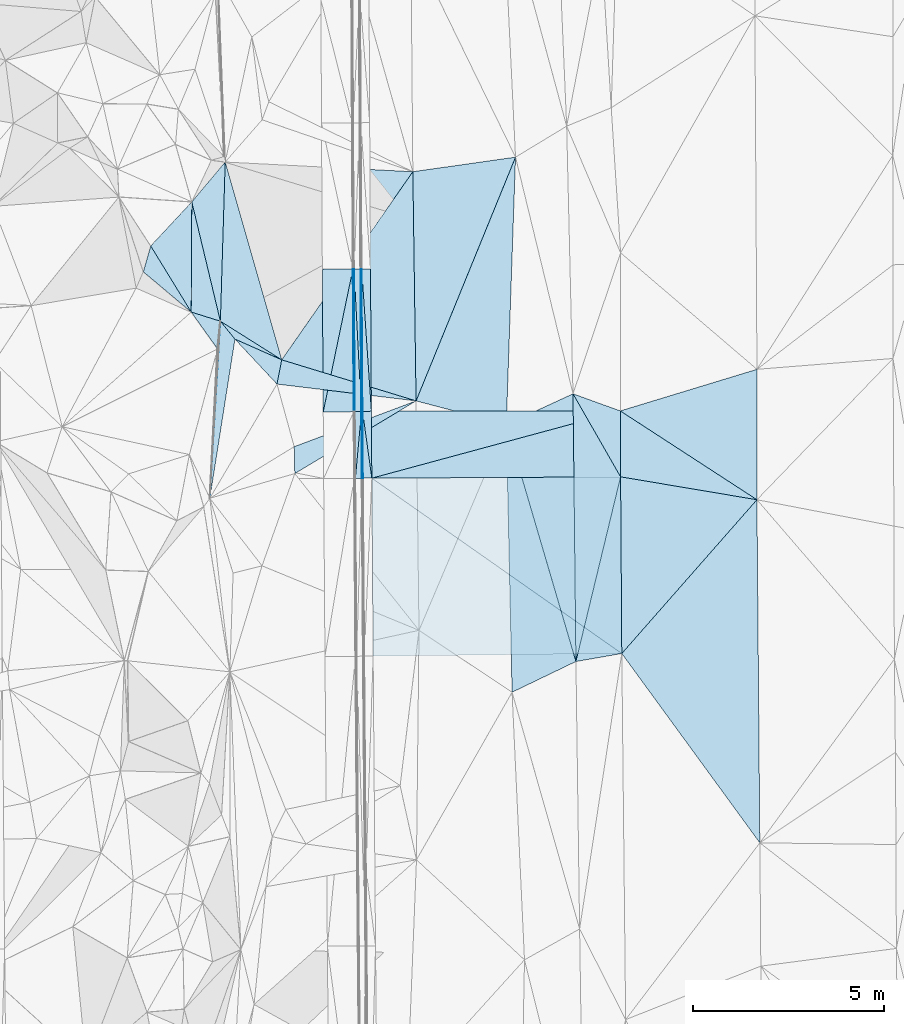
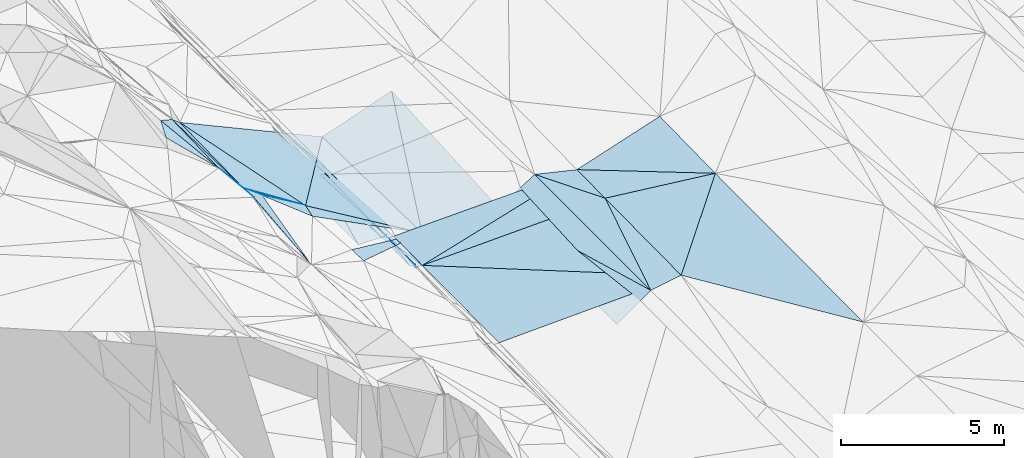
# One storey, part 55 of 275: 45 plates.
"""IFC2X3 building model written with IfcOpenShell, lengths in millimetres."""

from ifc_helpers import new_model, si_unit, frame, origin_with_axes, place, context, subcontext, project, spatial, polyline, outline, extrude, material, type_object, element, save


model = new_model("IFC2X3")

# Units and contexts
model_context = context("Model", 3, precision=1e-05, world=origin_with_axes())
body_context = subcontext(model_context, "Body", "Model", "MODEL_VIEW")
ifc_project = project(units=[si_unit("LENGTHUNIT", "METRE", prefix="MILLI"), si_unit("AREAUNIT", "SQUARE_METRE"), si_unit("VOLUMEUNIT", "CUBIC_METRE"), si_unit("MASSUNIT", "GRAM", prefix="KILO"), si_unit("TIMEUNIT", "SECOND"), si_unit("PLANEANGLEUNIT", "RADIAN"), si_unit("SOLIDANGLEUNIT", "STERADIAN"), si_unit("THERMODYNAMICTEMPERATUREUNIT", "DEGREE_CELSIUS"), si_unit("LUMINOUSINTENSITYUNIT", "LUMEN")], contexts=[model_context])

# Site, building, storey
site_placement = place(None, origin_with_axes())
site = spatial("IfcSite", under=ifc_project, at=site_placement, CompositionType="ELEMENT")
building_placement = place(site_placement, origin_with_axes())
building = spatial("IfcBuilding", under=site, at=building_placement, Name="Undefined", CompositionType="ELEMENT")
storey_placement = place(building_placement, origin_with_axes())
storey = spatial("IfcBuildingStorey", under=building, at=storey_placement, Name="Undefined", CompositionType="ELEMENT", Elevation=0.0)

# Plates
ifc_material = material()
plate_type_1 = type_object("IfcPlateType", PredefinedType="NOTDEFINED")
plate_1_placement = place(storey_placement, frame((-87254.3961921411, 43412.3524133345, 42029.5001328139), z_axis=(0.0169481786043907, 0.0174719834123439, -0.999703700622156), x_axis=(0.838479926946781, -0.544912289163529, 0.00469139913928916)))
element("IfcPlate", 1, at=plate_1_placement, inside=storey, type_object=plate_type_1, material=ifc_material, Name="00", context=body_context, shape_type="SweptSolid", body=[
    extrude(outline(polyline([(0.0, 0.0), (4263.12109375, -1.10921973828226e-08), (945.856323242188, 1441.7890625), (0.0, 0.0)])), frame((-8.85201319254618e-08, 2.18876761149539e-07, -0.5000001331573), z_axis=(0.0, 0.0, 1.0), x_axis=(1.0, 0.0, 0.0)), (0.0, 0.0, 1.0), 1.0),
])
plate_type_2 = type_object("IfcPlateType", PredefinedType="NOTDEFINED")
plate_2_placement = place(storey_placement, frame((-88491.2245056251, 43860.518521288, 42013.5001522304), z_axis=(0.0192664372360064, 0.0174817173264035, -0.999661539700088), x_axis=(0.940111482346545, -0.340650109450754, 0.0121615661561808)))
element("IfcPlate", 2, at=plate_2_placement, inside=storey, type_object=plate_type_2, material=ifc_material, Name="00", context=body_context, shape_type="SweptSolid", body=[
    extrude(outline(polyline([(0.0, 0.0), (1315.61999511719, 9.36597643885762e-09), (1909.87976074219, 1618.72033691406), (0.0, 0.0)])), frame((-8.85201319254618e-08, 2.18876761149539e-07, -0.5000001331573), z_axis=(0.0, 0.0, 1.0), x_axis=(1.0, 0.0, 0.0)), (0.0, 0.0, 1.0), 1.0),
])
plate_type_3 = type_object("IfcPlateType", PredefinedType="NOTDEFINED")
plate_3_placement = place(storey_placement, frame((-93996.071474144, 43393.196795718, 41807.7217446495), z_axis=(-0.970148303264862, -0.000346135526310684, -0.242512164359867), x_axis=(-0.242509549069597, -0.00347385898614747, 0.970142799238239)))
element("IfcPlate", 3, at=plate_3_placement, inside=storey, type_object=plate_type_3, material=ifc_material, Name="00_PR", context=body_context, shape_type="SweptSolid", body=[
    extrude(outline(polyline([(0.0, 0.0), (123.693099975586, 3.20142135024071e-10), (202.055953979492, 3731.91235351563), (0.0, 0.0)])), frame((-8.85201319254618e-08, 2.18876761149539e-07, -0.5000001331573), z_axis=(0.0, 0.0, 1.0), x_axis=(1.0, 0.0, 0.0)), (0.0, 0.0, 1.0), 1.0),
])
plate_4_placement = place(storey_placement, frame((-93996.071474144, 43393.196795718, 41807.7217446495), z_axis=(-0.970151593446318, -0.000346916917053302, -0.24249900078603), x_axis=(-0.0142874581057191, 0.998343602639594, 0.0557307779370935)))
element("IfcPlate", 4, at=plate_4_placement, inside=storey, type_object=plate_type_3, material=ifc_material, Name="00_PR", context=body_context, shape_type="SweptSolid", body=[
    extrude(outline(polyline([(0.0, 0.0), (3737.37841796875, -6.90488377586007e-09), (3730.77661132813, 123.516723632813), (0.0, 0.0)])), frame((-8.85201319254618e-08, 2.18876761149539e-07, -0.5000001331573), z_axis=(0.0, 0.0, 1.0), x_axis=(1.0, 0.0, 0.0)), (0.0, 0.0, 1.0), 1.0),
])
plate_type_4 = type_object("IfcPlateType", PredefinedType="NOTDEFINED")
plate_5_placement = place(storey_placement, frame((-94218.9907484026, 47123.3828426637, 42015.630240047), z_axis=(-0.0201305263028214, 0.0235208097565978, -0.999520651822245), x_axis=(-0.00176735889546842, -0.999722510493535, -0.0234899649858866)))
element("IfcPlate", 5, at=plate_5_placement, inside=storey, type_object=plate_type_4, material=ifc_material, Name="00_PR", context=body_context, shape_type="SweptSolid", body=[
    extrude(outline(polyline([(0.0, 0.0), (3732.95581054688, -1.17870513349772e-08), (0.217264458537102, 30.0053672790527), (0.0, 0.0)])), frame((-8.85201319254618e-08, 2.18876761149539e-07, -0.5000001331573), z_axis=(0.0, 0.0, 1.0), x_axis=(1.0, 0.0, 0.0)), (0.0, 0.0, 1.0), 1.0),
])
plate_6_placement = place(storey_placement, frame((-94225.5882306935, 43391.4629588264, 41927.9432410084), z_axis=(-0.0201456163364446, 0.0235207077893914, -0.999520350191786), x_axis=(0.00176735888982767, 0.999722510494012, 0.0234899649660288)))
element("IfcPlate", 6, at=plate_6_placement, inside=storey, type_object=plate_type_4, material=ifc_material, Name="00_PR", context=body_context, shape_type="SweptSolid", body=[
    extrude(outline(polyline([(0.0, 0.0), (3732.95581054688, -1.17870513349772e-08), (0.236551240086555, 30.0044651031494), (0.0, 0.0)])), frame((-8.85201319254618e-08, 2.18876761149539e-07, -0.5000001331573), z_axis=(0.0, 0.0, 1.0), x_axis=(1.0, 0.0, 0.0)), (0.0, 0.0, 1.0), 1.0),
])
plate_type_5 = type_object("IfcPlateType", PredefinedType="NOTDEFINED")
plate_7_placement = place(storey_placement, frame((-95025.5713508641, 43386.1983303903, 41943.943239241), z_axis=(-0.0201456163364446, 0.0235207077893914, -0.999520350191786), x_axis=(0.203425101921867, 0.978907387213528, 0.0189355529853638)))
element("IfcPlate", 7, at=plate_7_placement, inside=storey, type_object=plate_type_5, material=ifc_material, Name="00_PR", context=body_context, shape_type="SweptSolid", body=[
    extrude(outline(polyline([(0.0, 0.0), (3817.52783203125, -1.5905243344605e-08), (167.587249755859, 782.413696289063), (0.0, 0.0)])), frame((-8.85201319254618e-08, 2.18876761149539e-07, -0.5000001331573), z_axis=(0.0, 0.0, 1.0), x_axis=(1.0, 0.0, 0.0)), (0.0, 0.0, 1.0), 1.0),
])
plate_8_placement = place(storey_placement, frame((-94248.9903728565, 47123.2044534739, 42016.2302397834), z_axis=(-0.0201309808787363, 0.0235176734997545, -0.999520716464656), x_axis=(-0.20342510193904, -0.978907387210058, -0.0189355529802902)))
element("IfcPlate", 8, at=plate_8_placement, inside=storey, type_object=plate_type_5, material=ifc_material, Name="00_PR", context=body_context, shape_type="SweptSolid", body=[
    extrude(outline(polyline([(0.0, 0.0), (3817.52783203125, -1.5905243344605e-08), (167.102905273438, 782.516662597656), (0.0, 0.0)])), frame((-8.85201319254618e-08, 2.18876761149539e-07, -0.5000001331573), z_axis=(0.0, 0.0, 1.0), x_axis=(1.0, 0.0, 0.0)), (0.0, 0.0, 1.0), 1.0),
])
plate_type_6 = type_object("IfcPlateType", PredefinedType="NOTDEFINED")
plate_9_placement = place(storey_placement, frame((-93984.3799991826, 41652.6045620513, 41771.1807437658), z_axis=(-0.970146467083802, -0.00142519384262152, -0.242515569041098), x_axis=(-0.0238533901221872, 0.995694809502408, 0.0895704310006481)))
element("IfcPlate", 9, at=plate_9_placement, inside=storey, type_object=plate_type_6, material=ifc_material, Name="00_PR", context=body_context, shape_type="SweptSolid", body=[
    extrude(outline(polyline([(0.0, 0.0), (1747.68615722656, -7.71251507103443e-10), (1736.65002441406, 123.199813842773), (0.0, 0.0)])), frame((-8.85201319254618e-08, 2.18876761149539e-07, -0.5000001331573), z_axis=(0.0, 0.0, 1.0), x_axis=(1.0, 0.0, 0.0)), (0.0, 0.0, 1.0), 1.0),
])
plate_10_placement = place(storey_placement, frame((-94014.3571374174, 41651.5789155878, 41891.1808151741), z_axis=(-0.970182111727418, -0.00143888621951167, -0.242372852627053), x_axis=(-0.00672430410982141, 0.999757257952698, 0.0209811559534014)))
element("IfcPlate", 10, at=plate_10_placement, inside=storey, type_object=plate_type_6, material=ifc_material, Name="00_PR", context=body_context, shape_type="SweptSolid", body=[
    extrude(outline(polyline([(0.0, 0.0), (1741.6103515625, -3.25235305353999e-09), (-1.69392347335815, 123.680274963379), (0.0, 0.0)])), frame((-8.85201319254618e-08, 2.18876761149539e-07, -0.5000001331573), z_axis=(0.0, 0.0, 1.0), x_axis=(1.0, 0.0, 0.0)), (0.0, 0.0, 1.0), 1.0),
])
plate_type_7 = type_object("IfcPlateType", PredefinedType="NOTDEFINED")
plate_11_placement = place(storey_placement, frame((-93765.6485033998, 43406.0201116533, 41814.9273653451), z_axis=(0.03178552070704, 0.0210955538332301, -0.999272064195658), x_axis=(0.00672342711645003, -0.999759131487965, -0.0208919729618778)))
element("IfcPlate", 11, at=plate_11_placement, inside=storey, type_object=plate_type_7, material=ifc_material, Name="00_PR", context=body_context, shape_type="SweptSolid", body=[
    extrude(outline(polyline([(0.0, 0.0), (1753.06567382813, 5.3114490583539e-09), (11.4220886230469, 230.12028503418), (0.0, 0.0)])), frame((-8.85201319254618e-08, 2.18876761149539e-07, -0.5000001331573), z_axis=(0.0, 0.0, 1.0), x_axis=(1.0, 0.0, 0.0)), (0.0, 0.0, 1.0), 1.0),
])
plate_12_placement = place(storey_placement, frame((-94018.972792968, 47124.9119329478, 41895.6304075136), z_axis=(0.0324746987268286, 0.0238953047829369, -0.999186873588686), x_axis=(0.999458663599886, 0.00449495810727437, 0.0325910280099316)))
element("IfcPlate", 12, at=plate_12_placement, inside=storey, type_object=plate_type_7, material=ifc_material, Name="00_PR", context=body_context, shape_type="SweptSolid", body=[
    extrude(outline(polyline([(0.0, 0.0), (230.12467956543, -2.69210431724787e-10), (233.841049194336, 3721.04150390625), (0.0, 0.0)])), frame((-8.85201319254618e-08, 2.18876761149539e-07, -0.5000001331573), z_axis=(0.0, 0.0, 1.0), x_axis=(1.0, 0.0, 0.0)), (0.0, 0.0, 1.0), 1.0),
])
plate_13_placement = place(storey_placement, frame((-94018.9732155198, 47124.9119031071, 41895.630393713), z_axis=(0.0316307987550433, 0.023838435977211, -0.999215302895366), x_axis=(0.0679449250781449, -0.997454237515661, -0.0216455819551299)))
element("IfcPlate", 13, at=plate_13_placement, inside=storey, type_object=plate_type_7, material=ifc_material, Name="00_PR", context=body_context, shape_type="SweptSolid", body=[
    extrude(outline(polyline([(0.0, 0.0), (3728.38208007813, -7.74161890149117e-09), (3725.7041015625, 230.38801574707), (0.0, 0.0)])), frame((-8.85201319254618e-08, 2.18876761149539e-07, -0.5000001331573), z_axis=(0.0, 0.0, 1.0), x_axis=(1.0, 0.0, 0.0)), (0.0, 0.0, 1.0), 1.0),
])
plate_type_8 = type_object("IfcPlateType", PredefinedType="NOTDEFINED")
plate_14_placement = place(storey_placement, frame((-93995.5701433296, 43393.2075686393, 41807.3433781474), z_axis=(0.0325115803379931, 0.021195997758632, -0.999246579590314), x_axis=(0.137586124119793, -0.990351852039465, -0.0165308079564748)))
element("IfcPlate", 14, at=plate_14_placement, inside=storey, type_object=plate_type_8, material=ifc_material, Name="00_PR", context=body_context, shape_type="SweptSolid", body=[
    extrude(outline(polyline([(0.0, 0.0), (1756.78039550781, 5.68979885429144e-09), (1726.01086425781, 228.074432373047), (0.0, 0.0)])), frame((-8.85201319254618e-08, 2.18876761149539e-07, -0.5000001331573), z_axis=(0.0, 0.0, 1.0), x_axis=(1.0, 0.0, 0.0)), (0.0, 0.0, 1.0), 1.0),
])
plate_type_9 = type_object("IfcPlateType", PredefinedType="NOTDEFINED")
plate_15_placement = place(storey_placement, frame((-90236.5363911978, 43055.0183060786, 41864.5015295074), z_axis=(0.0761176880402497, 0.0194762135708598, -0.996908608986977), x_axis=(0.905251947049105, 0.417787601630124, 0.0772815132354067)))
element("IfcPlate", 15, at=plate_15_placement, inside=storey, type_object=plate_type_9, material=ifc_material, Name="00", context=body_context, shape_type="SweptSolid", body=[
    extrude(outline(polyline([(0.0, 0.0), (1928.01611328125, 3.21597326546907e-09), (-938.971923828125, 6391.26611328125), (0.0, 0.0)])), frame((-8.85201319254618e-08, 2.18876761149539e-07, -0.5000001331573), z_axis=(0.0, 0.0, 1.0), x_axis=(1.0, 0.0, 0.0)), (0.0, 0.0, 1.0), 1.0),
])
plate_type_10 = type_object("IfcPlateType", PredefinedType="NOTDEFINED")
plate_16_placement = place(storey_placement, frame((-92596.5508050749, 43674.6404654156, 41362.5102365883), z_axis=(0.20142719387511, 0.00398515522973663, -0.979495382380843), x_axis=(-0.0141059625902572, 0.999899824518128, 0.0011673679876357)))
element("IfcPlate", 16, at=plate_16_placement, inside=storey, type_object=plate_type_10, material=ifc_material, Name="00", context=body_context, shape_type="SweptSolid", body=[
    extrude(outline(polyline([(0.0, 0.0), (5996.3974609375, -7.11588654667139e-09), (6339.8720703125, 2747.89111328125), (0.0, 0.0)])), frame((-8.85201319254618e-08, 2.18876761149539e-07, -0.5000001331573), z_axis=(0.0, 0.0, 1.0), x_axis=(1.0, 0.0, 0.0)), (0.0, 0.0, 1.0), 1.0),
])
plate_type_11 = type_object("IfcPlateType", PredefinedType="NOTDEFINED")
plate_17_placement = place(storey_placement, frame((-94025.5832430627, 43392.7791016036, 41927.3431406311), z_axis=(-0.00015559819629217, 0.0236509191248462, -0.999720265781259), x_axis=(-0.999978359414222, -0.00657880712899669, -6.29156613133342e-12)))
element("IfcPlate", 17, at=plate_17_placement, inside=storey, type_object=plate_type_11, material=ifc_material, Name="00_PR", context=body_context, shape_type="SweptSolid", body=[
    extrude(outline(polyline([(0.0, 0.0), (169.999923706055, 1.02591002359986e-09), (168.85041809082, 3732.83959960938), (0.0, 0.0)])), frame((-8.85201319254618e-08, 2.18876761149539e-07, -0.5000001331573), z_axis=(0.0, 0.0, 1.0), x_axis=(1.0, 0.0, 0.0)), (0.0, 0.0, 1.0), 1.0),
])
plate_18_placement = place(storey_placement, frame((-94025.5832360626, 43392.777766791, 41927.3431110743), z_axis=(-0.000144221316183831, 0.0209806605033919, -0.999779871314208), x_axis=(0.00672430411002196, -0.999757257952617, -0.0209811559571823)))
element("IfcPlate", 18, at=plate_18_placement, inside=storey, type_object=plate_type_11, material=ifc_material, Name="00_PR", context=body_context, shape_type="SweptSolid", body=[
    extrude(outline(polyline([(0.0, 0.0), (1741.6103515625, -3.25235305353999e-09), (1741.63562011719, 169.999954223633), (0.0, 0.0)])), frame((-8.85201319254618e-08, 2.18876761149539e-07, -0.5000001331573), z_axis=(0.0, 0.0, 1.0), x_axis=(1.0, 0.0, 0.0)), (0.0, 0.0, 1.0), 1.0),
])
plate_19_placement = place(storey_placement, frame((-94025.5832430627, 43392.7791016036, 41927.3431406311), z_axis=(-0.000141024271216346, 0.0236516747445903, -0.999720250066953), x_axis=(-0.0517568361200484, 0.998380179057239, 0.0236272719643521)))
element("IfcPlate", 19, at=plate_19_placement, inside=storey, type_object=plate_type_11, material=ifc_material, Name="00_PR", context=body_context, shape_type="SweptSolid", body=[
    extrude(outline(polyline([(0.0, 0.0), (3736.65649414063, 4.84578777104616e-09), (3728.8701171875, 169.821258544922), (0.0, 0.0)])), frame((-8.85201319254618e-08, 2.18876761149539e-07, -0.5000001331573), z_axis=(0.0, 0.0, 1.0), x_axis=(1.0, 0.0, 0.0)), (0.0, 0.0, 1.0), 1.0),
])
plate_20_placement = place(storey_placement, frame((-94183.8680531571, 41650.4215675436, 41890.8021115084), z_axis=(-0.000138026669983402, 0.020980098158715, -0.999779883989415), x_axis=(-0.00672430410982141, 0.999757257952698, 0.0209811559534014)))
element("IfcPlate", 20, at=plate_20_placement, inside=storey, type_object=plate_type_11, material=ifc_material, Name="00_PR", context=body_context, shape_type="SweptSolid", body=[
    extrude(outline(polyline([(0.0, 0.0), (1741.66052246094, 3.30328475683928e-09), (1741.63562011719, 169.999954223633), (0.0, 0.0)])), frame((-8.85201319254618e-08, 2.18876761149539e-07, -0.5000001331573), z_axis=(0.0, 0.0, 1.0), x_axis=(1.0, 0.0, 0.0)), (0.0, 0.0, 1.0), 1.0),
])
plate_type_12 = type_object("IfcPlateType", PredefinedType="NOTDEFINED")
plate_21_placement = place(storey_placement, frame((-87254.3896793601, 43412.3539298788, 42008.2723295409), z_axis=(0.0297986103659708, 0.02054831953261, -0.999344689976708), x_axis=(0.00451385910555291, -0.999781245253875, -0.0204227009620972)))
element("IfcPlate", 21, at=plate_21_placement, inside=storey, type_object=plate_type_12, material=ifc_material, Name="00_PR", context=body_context, shape_type="SweptSolid", body=[
    extrude(outline(polyline([(0.0, 0.0), (1724.45361328125, 4.39467839896679e-09), (1733.95153808594, 6510.25732421875), (0.0, 0.0)])), frame((-8.85201319254618e-08, 2.18876761149539e-07, -0.5000001331573), z_axis=(0.0, 0.0, 1.0), x_axis=(1.0, 0.0, 0.0)), (0.0, 0.0, 1.0), 1.0),
])
plate_type_13 = type_object("IfcPlateType", PredefinedType="NOTDEFINED")
plate_22_placement = place(storey_placement, frame((-87246.6057390961, 41688.2775807945, 41973.0543304866), z_axis=(0.0297980798070713, 0.0206370042420111, -0.999342878343428), x_axis=(0.0068223381032197, -0.999767756005966, -0.0204423519586338)))
element("IfcPlate", 22, at=plate_22_placement, inside=storey, type_object=plate_type_13, material=ifc_material, Name="00_PR", context=body_context, shape_type="SweptSolid", body=[
    extrude(outline(polyline([(0.0, 0.0), (4623.0, 1.27765815705061e-08), (-5.52057123184204, 6510.26220703125), (0.0, 0.0)])), frame((-8.85201319254618e-08, 2.18876761149539e-07, -0.5000001331573), z_axis=(0.0, 0.0, 1.0), x_axis=(1.0, 0.0, 0.0)), (0.0, 0.0, 1.0), 1.0),
])
plate_type_14 = type_object("IfcPlateType", PredefinedType="NOTDEFINED")
plate_23_placement = place(storey_placement, frame((-93753.8629607056, 41653.3767474164, 41778.3023325321), z_axis=(0.0296537764124337, 0.0210825929112354, -0.999337869702045), x_axis=(-0.00672342711752918, 0.999759131487532, 0.020891972982269)))
element("IfcPlate", 23, at=plate_23_placement, inside=storey, type_object=plate_type_14, material=ifc_material, Name="00_PR", context=body_context, shape_type="SweptSolid", body=[
    extrude(outline(polyline([(0.0, 0.0), (1753.06567382813, 5.3114490583539e-09), (1719.65954589844, 6514.04736328125), (0.0, 0.0)])), frame((-8.85201319254618e-08, 2.18876761149539e-07, -0.5000001331573), z_axis=(0.0, 0.0, 1.0), x_axis=(1.0, 0.0, 0.0)), (0.0, 0.0, 1.0), 1.0),
])
plate_type_15 = type_object("IfcPlateType", PredefinedType="NOTDEFINED")
plate_24_placement = place(storey_placement, frame((-93720.0758234974, 36997.7422771014, 41683.1683301032), z_axis=(0.0297980798070713, 0.0206370042420111, -0.999342878343428), x_axis=(-0.00725548811011348, 0.99976498987344, 0.0204284829501307)))
element("IfcPlate", 24, at=plate_24_placement, inside=storey, type_object=plate_type_15, material=ifc_material, Name="00_PR", context=body_context, shape_type="SweptSolid", body=[
    extrude(outline(polyline([(0.0, 0.0), (4656.728515625, 3.33238858729601e-09), (25.3867778778076, 6508.25537109375), (0.0, 0.0)])), frame((-8.85201319254618e-08, 2.18876761149539e-07, -0.5000001331573), z_axis=(0.0, 0.0, 1.0), x_axis=(1.0, 0.0, 0.0)), (0.0, 0.0, 1.0), 1.0),
])
plate_type_16 = type_object("IfcPlateType", PredefinedType="NOTDEFINED")
plate_25_placement = place(storey_placement, frame((-98463.2355650538, 48881.2958307698, 44519.6723958988), z_axis=(-0.755195962236505, 0.0200535537784526, -0.655192272239634), x_axis=(0.223076952207303, -0.932008414909742, -0.285651864918351)))
element("IfcPlate", 25, at=plate_25_placement, inside=storey, type_object=plate_type_16, material=ifc_material, Name="00", context=body_context, shape_type="SweptSolid", body=[
    extrude(outline(polyline([(0.0, 0.0), (3350.23193359375, 3.81260178983212e-09), (2703.02172851563, 1003.92883300781), (0.0, 0.0)])), frame((-8.85201319254618e-08, 2.18876761149539e-07, -0.5000001331573), z_axis=(0.0, 0.0, 1.0), x_axis=(1.0, 0.0, 0.0)), (0.0, 0.0, 1.0), 1.0),
])
plate_type_17 = type_object("IfcPlateType", PredefinedType="NOTDEFINED")
plate_26_placement = place(storey_placement, frame((-98479.0523026678, 45998.7218496765, 44449.6775749264), z_axis=(-0.763091644867988, -0.0433622065221483, -0.644833979081592), x_axis=(0.638922323103652, -0.200844277917183, -0.742589954865912)))
element("IfcPlate", 26, at=plate_26_placement, inside=storey, type_object=plate_type_17, material=ifc_material, Name="00", context=body_context, shape_type="SweptSolid", body=[
    extrude(outline(polyline([(0.0, 0.0), (1194.46813964844, -5.3987605497241e-09), (1190.46301269531, 740.606506347656), (0.0, 0.0)])), frame((-8.85201319254618e-08, 2.18876761149539e-07, -0.5000001331573), z_axis=(0.0, 0.0, 1.0), x_axis=(1.0, 0.0, 0.0)), (0.0, 0.0, 1.0), 1.0),
])
plate_type_18 = type_object("IfcPlateType", PredefinedType="NOTDEFINED")
plate_27_placement = place(storey_placement, frame((-97991.6627483668, 41127.7760431754, 43596.5191433836), z_axis=(-0.27401332176155, 0.00927171773765619, -0.961681202242924), x_axis=(0.0594961472829212, 0.998201633617297, -0.00732851296292725)))
element("IfcPlate", 27, at=plate_27_placement, inside=storey, type_object=plate_type_18, material=ifc_material, Name="00", context=body_context, shape_type="SweptSolid", body=[
    extrude(outline(polyline([(0.0, 0.0), (4639.41357421875, 4.30736690759659e-09), (4195.7255859375, 424.1640625), (0.0, 0.0)])), frame((-8.85201319254618e-08, 2.18876761149539e-07, -0.5000001331573), z_axis=(0.0, 0.0, 1.0), x_axis=(1.0, 0.0, 0.0)), (0.0, 0.0, 1.0), 1.0),
])
plate_type_19 = type_object("IfcPlateType", PredefinedType="NOTDEFINED")
plate_28_placement = place(storey_placement, frame((-92596.8284920145, 43674.6344783323, 41362.5323788082), z_axis=(-0.353999256471033, -0.00798857083114477, -0.935211585233006), x_axis=(-0.814787695389495, -0.488272950368339, 0.31258684774071)))
element("IfcPlate", 28, at=plate_28_placement, inside=storey, type_object=plate_type_19, material=ifc_material, Name="00", context=body_context, shape_type="SweptSolid", body=[
    extrude(outline(polyline([(0.0, 0.0), (3893.31811523438, -6.95581547915936e-09), (3562.67456054688, 621.349304199219), (0.0, 0.0)])), frame((-8.85201319254618e-08, 2.18876761149539e-07, -0.5000001331573), z_axis=(0.0, 0.0, 1.0), x_axis=(1.0, 0.0, 0.0)), (0.0, 0.0, 1.0), 1.0),
])
plate_type_20 = type_object("IfcPlateType", PredefinedType="NOTDEFINED")
plate_29_placement = place(storey_placement, frame((-96111.4775263115, 44749.2738724638, 42969.5320587538), z_axis=(-0.352253674769096, -0.0100288854653798, -0.935850826824441), x_axis=(-0.80774074429365, 0.508332067389091, 0.298585664880069)))
element("IfcPlate", 29, at=plate_29_placement, inside=storey, type_object=plate_type_20, material=ifc_material, Name="00", context=body_context, shape_type="SweptSolid", body=[
    extrude(outline(polyline([(0.0, 0.0), (1986.02966308594, 6.78119249641895e-09), (3973.8544921875, 3662.78344726563), (0.0, 0.0)])), frame((-8.85201319254618e-08, 2.18876761149539e-07, -0.5000001331573), z_axis=(0.0, 0.0, 1.0), x_axis=(1.0, 0.0, 0.0)), (0.0, 0.0, 1.0), 1.0),
])
plate_type_21 = type_object("IfcPlateType", PredefinedType="NOTDEFINED")
plate_30_placement = place(storey_placement, frame((-92596.8546841983, 43674.65662786, 41362.5434848101), z_axis=(-0.406344469702017, 0.0363182538275363, -0.912997895058639), x_axis=(-0.906460486387574, 0.109682327506381, 0.407797956898739)))
element("IfcPlate", 30, at=plate_30_placement, inside=storey, type_object=plate_type_21, material=ifc_material, Name="00", context=body_context, shape_type="SweptSolid", body=[
    extrude(outline(polyline([(0.0, 0.0), (4014.24267578125, -2.27846612688154e-08), (3959.09155273438, 644.715698242188), (0.0, 0.0)])), frame((-8.85201319254618e-08, 2.18876761149539e-07, -0.5000001331573), z_axis=(0.0, 0.0, 1.0), x_axis=(1.0, 0.0, 0.0)), (0.0, 0.0, 1.0), 1.0),
])
plate_type_22 = type_object("IfcPlateType", PredefinedType="NOTDEFINED")
plate_31_placement = place(storey_placement, frame((-97590.0299282107, 49923.3539626209, 43470.6828715729), z_axis=(-0.773078975395737, 0.00935182113420549, -0.634240838516846), x_axis=(-0.0301997168128904, -0.99930006906499, 0.0220759840353356)))
element("IfcPlate", 31, at=plate_31_placement, inside=storey, type_object=plate_type_22, material=ifc_material, Name="00", context=body_context, shape_type="SweptSolid", body=[
    extrude(outline(polyline([(0.0, 0.0), (4167.4248046875, 1.35769369080663e-08), (1090.86267089844, 1326.20495605469), (0.0, 0.0)])), frame((-8.85201319254618e-08, 2.18876761149539e-07, -0.5000001331573), z_axis=(0.0, 0.0, 1.0), x_axis=(1.0, 0.0, 0.0)), (0.0, 0.0, 1.0), 1.0),
])
plate_type_23 = type_object("IfcPlateType", PredefinedType="NOTDEFINED")
plate_32_placement = place(storey_placement, frame((-98478.8590919555, 45998.9064385043, 44449.5664128952), z_axis=(-0.376671089774012, 0.325815768719814, -0.867157987325248), x_axis=(-0.663766560478599, 0.55804455816673, 0.49799620911299)))
element("IfcPlate", 32, at=plate_32_placement, inside=storey, type_object=plate_type_23, material=ifc_material, Name="00", context=body_context, shape_type="SweptSolid", body=[
    extrude(outline(polyline([(0.0, 0.0), (1887.56457519531, 5.34782884642482e-09), (2221.11596679688, 641.67236328125), (0.0, 0.0)])), frame((-8.85201319254618e-08, 2.18876761149539e-07, -0.5000001331573), z_axis=(0.0, 0.0, 1.0), x_axis=(1.0, 0.0, 0.0)), (0.0, 0.0, 1.0), 1.0),
])
plate_type_24 = type_object("IfcPlateType", PredefinedType="NOTDEFINED")
plate_33_placement = place(storey_placement, frame((-87246.6098213395, 41688.2767516772, 41999.500193151), z_axis=(0.0218040845668258, 0.0189351866790013, -0.999582933328513), x_axis=(-0.235014146383662, -0.971707015324432, -0.0235335371086033)))
element("IfcPlate", 33, at=plate_33_placement, inside=storey, type_object=plate_type_24, material=ifc_material, Name="00", context=body_context, shape_type="SweptSolid", body=[
    extrude(outline(polyline([(0.0, 0.0), (4971.62841796875, -1.16851879283786e-08), (-1818.61096191406, 1720.62487792969), (0.0, 0.0)])), frame((-8.85201319254618e-08, 2.18876761149539e-07, -0.5000001331573), z_axis=(0.0, 0.0, 1.0), x_axis=(1.0, 0.0, 0.0)), (0.0, 0.0, 1.0), 1.0),
])
plate_type_25 = type_object("IfcPlateType", PredefinedType="NOTDEFINED")
plate_34_placement = place(storey_placement, frame((-87215.0758579352, 37066.3515612032, 41899.5001291112), z_axis=(0.0103828265469322, 0.0217005896756133, -0.999710598783782), x_axis=(-0.985066719088075, -0.171606512695113, -0.0139557782182963)))
element("IfcPlate", 34, at=plate_34_placement, inside=storey, type_object=plate_type_25, material=ifc_material, Name="00", context=body_context, shape_type="SweptSolid", body=[
    extrude(outline(polyline([(0.0, 0.0), (1218.13342285156, 5.89352566748858e-10), (-763.479614257813, 4559.63818359375), (0.0, 0.0)])), frame((-8.85201319254618e-08, 2.18876761149539e-07, -0.5000001331573), z_axis=(0.0, 0.0, 1.0), x_axis=(1.0, 0.0, 0.0)), (0.0, 0.0, 1.0), 1.0),
])
plate_type_26 = type_object("IfcPlateType", PredefinedType="NOTDEFINED")
plate_35_placement = place(storey_placement, frame((-83679.8530095518, 41089.3262504089, 42049.5001836388), z_axis=(0.0206704095006933, 0.0191067921323881, -0.999603753827227), x_axis=(0.00844194767478565, -0.999785063481769, -0.0189356900643081)))
element("IfcPlate", 35, at=plate_35_placement, inside=storey, type_object=plate_type_26, material=ifc_material, Name="00", context=body_context, shape_type="SweptSolid", body=[
    extrude(outline(polyline([(0.0, 0.0), (8977.755859375, 2.47673597186804e-08), (3995.107421875, 3569.83422851563), (0.0, 0.0)])), frame((-8.85201319254618e-08, 2.18876761149539e-07, -0.5000001331573), z_axis=(0.0, 0.0, 1.0), x_axis=(1.0, 0.0, 0.0)), (0.0, 0.0, 1.0), 1.0),
])
plate_type_27 = type_object("IfcPlateType", PredefinedType="NOTDEFINED")
plate_36_placement = place(storey_placement, frame((-83679.2480257203, 44500.8954507211, 42119.500180069), z_axis=(0.0189201050652378, 0.0205070727344175, -0.999610669006782), x_axis=(-0.00017755232442975, -0.999789547880314, -0.020514103062245)))
element("IfcPlate", 36, at=plate_36_placement, inside=storey, type_object=plate_type_27, material=ifc_material, Name="00", context=body_context, shape_type="SweptSolid", body=[
    extrude(outline(polyline([(0.0, 0.0), (3412.28662109375, -1.21508492156863e-08), (1090.79345703125, 3575.59350585938), (0.0, 0.0)])), frame((-8.85201319254618e-08, 2.18876761149539e-07, -0.5000001331573), z_axis=(0.0, 0.0, 1.0), x_axis=(1.0, 0.0, 0.0)), (0.0, 0.0, 1.0), 1.0),
])
plate_type_28 = type_object("IfcPlateType", PredefinedType="NOTDEFINED")
plate_37_placement = place(storey_placement, frame((-97715.9840759802, 45758.8695633624, 43562.8839293181), z_axis=(-0.971067427896264, 0.056174813853102, -0.232104374727199), x_axis=(-0.0594961474527236, -0.998201633607114, 0.00732851297141802)))
element("IfcPlate", 37, at=plate_37_placement, inside=storey, type_object=plate_type_28, material=ifc_material, Name="00", context=body_context, shape_type="SweptSolid", body=[
    extrude(outline(polyline([(0.0, 0.0), (4639.41357421875, 4.30736690759659e-09), (728.141845703125, 135.364212036133), (0.0, 0.0)])), frame((-8.85201319254618e-08, 2.18876761149539e-07, -0.5000001331573), z_axis=(0.0, 0.0, 1.0), x_axis=(1.0, 0.0, 0.0)), (0.0, 0.0, 1.0), 1.0),
])
plate_type_29 = type_object("IfcPlateType", PredefinedType="NOTDEFINED")
plate_38_placement = place(storey_placement, frame((-96235.5816294837, 44114.9426296262, 42999.5327941046), z_axis=(-0.355374856100537, 0.0253354409733087, -0.934380450931103), x_axis=(-0.657712321591335, 0.703514447631489, 0.269224671976209)))
element("IfcPlate", 38, at=plate_38_placement, inside=storey, type_object=plate_type_29, material=ifc_material, Name="00", context=body_context, shape_type="SweptSolid", body=[
    extrude(outline(polyline([(0.0, 0.0), (1671.46643066406, -1.01208570413291e-08), (356.573120117188, 539.958923339844), (0.0, 0.0)])), frame((-8.85201319254618e-08, 2.18876761149539e-07, -0.5000001331573), z_axis=(0.0, 0.0, 1.0), x_axis=(1.0, 0.0, 0.0)), (0.0, 0.0, 1.0), 1.0),
])
plate_type_30 = type_object("IfcPlateType", PredefinedType="NOTDEFINED")
plate_39_placement = place(storey_placement, frame((-98479.0241452776, 45998.7540764655, 44449.6463169354), z_axis=(-0.706568828683204, 0.0210529437992462, -0.707331085058922), x_axis=(-0.458347209420247, 0.747935591579951, 0.480114763847793)))
element("IfcPlate", 39, at=plate_39_placement, inside=storey, type_object=plate_type_30, material=ifc_material, Name="00", context=body_context, shape_type="SweptSolid", body=[
    extrude(outline(polyline([(0.0, 0.0), (2311.947265625, 1.34605215862393e-09), (2182.31616210938, 1884.59436035156), (0.0, 0.0)])), frame((-8.85201319254618e-08, 2.18876761149539e-07, -0.5000001331573), z_axis=(0.0, 0.0, 1.0), x_axis=(1.0, 0.0, 0.0)), (0.0, 0.0, 1.0), 1.0),
])
plate_type_31 = type_object("IfcPlateType", PredefinedType="NOTDEFINED")
plate_40_placement = place(storey_placement, frame((-96111.5038607091, 44749.2237523728, 42969.5461456214), z_axis=(-0.404922848877191, -0.110268915970435, -0.907677394577988), x_axis=(-0.860707509999812, 0.380987404270813, 0.337685030785956)))
element("IfcPlate", 40, at=plate_40_placement, inside=storey, type_object=plate_type_31, material=ifc_material, Name="00", context=body_context, shape_type="SweptSolid", body=[
    extrude(outline(polyline([(0.0, 0.0), (1421.44287109375, -2.9194779926911e-09), (1965.62231445313, 283.976684570313), (0.0, 0.0)])), frame((-8.85201319254618e-08, 2.18876761149539e-07, -0.5000001331573), z_axis=(0.0, 0.0, 1.0), x_axis=(1.0, 0.0, 0.0)), (0.0, 0.0, 1.0), 1.0),
])
plate_type_32 = type_object("IfcPlateType", PredefinedType="NOTDEFINED")
plate_41_placement = place(storey_placement, frame((-87246.6118916506, 41688.2781579861, 41999.500180937), z_axis=(0.017664890009641, 0.0217480495749906, -0.999607409936837), x_axis=(0.986097590377636, -0.165591227384272, 0.0138234461980723)))
element("IfcPlate", 41, at=plate_41_placement, inside=storey, type_object=plate_type_32, material=ifc_material, Name="00", context=body_context, shape_type="SweptSolid", body=[
    extrude(outline(polyline([(0.0, 0.0), (3617.04296875, -2.69210431724787e-10), (795.0693359375, 4554.23583984375), (0.0, 0.0)])), frame((-8.85201319254618e-08, 2.18876761149539e-07, -0.5000001331573), z_axis=(0.0, 0.0, 1.0), x_axis=(1.0, 0.0, 0.0)), (0.0, 0.0, 1.0), 1.0),
])
plate_type_33 = type_object("IfcPlateType", PredefinedType="NOTDEFINED")
plate_42_placement = place(storey_placement, frame((-89994.6874484742, 50051.1967654838, 41923.5109573685), z_axis=(0.208313890704642, 0.00104898548067404, -0.978061461549813), x_axis=(-0.0345373814508266, -0.99936787066272, -0.00842783302992819)))
element("IfcPlate", 42, at=plate_42_placement, inside=storey, type_object=plate_type_33, material=ifc_material, Name="00", context=body_context, shape_type="SweptSolid", body=[
    extrude(outline(polyline([(0.0, 0.0), (7000.61279296875, 2.62953108176589e-08), (6467.1162109375, 2433.3701171875), (0.0, 0.0)])), frame((-8.85201319254618e-08, 2.18876761149539e-07, -0.5000001331573), z_axis=(0.0, 0.0, 1.0), x_axis=(1.0, 0.0, 0.0)), (0.0, 0.0, 1.0), 1.0),
])
plate_type_34 = type_object("IfcPlateType", PredefinedType="NOTDEFINED")
plate_43_placement = place(storey_placement, frame((-88414.9676431626, 36857.316122993, 41882.503370908), z_axis=(0.112163590094232, 0.0300810339682107, -0.993234343170118), x_axis=(-0.89515394682322, -0.430896731511888, -0.114137716199264)))
element("IfcPlate", 43, at=plate_43_placement, inside=storey, type_object=plate_type_34, material=ifc_material, Name="00", context=body_context, shape_type="SweptSolid", body=[
    extrude(outline(polyline([(0.0, 0.0), (1866.16662597656, -7.05767888575792e-09), (-1037.94909667969, 6375.93994140625), (0.0, 0.0)])), frame((-8.85201319254618e-08, 2.18876761149539e-07, -0.5000001331573), z_axis=(0.0, 0.0, 1.0), x_axis=(1.0, 0.0, 0.0)), (0.0, 0.0, 1.0), 1.0),
])
plate_type_35 = type_object("IfcPlateType", PredefinedType="NOTDEFINED")
plate_44_placement = place(storey_placement, frame((-96111.509949909, 44749.2764746173, 42969.5455445826), z_axis=(-0.417038878814317, -0.00482222536250587, -0.908875854943815), x_axis=(0.552495673835142, 0.792672329645518, -0.257719048981251)))
element("IfcPlate", 44, at=plate_44_placement, inside=storey, type_object=plate_type_35, material=ifc_material, Name="00", context=body_context, shape_type="SweptSolid", body=[
    extrude(outline(polyline([(0.0, 0.0), (6208.31103515625, -2.91038304567337e-08), (1504.14562988281, 3718.54956054688), (0.0, 0.0)])), frame((-8.85201319254618e-08, 2.18876761149539e-07, -0.5000001331573), z_axis=(0.0, 0.0, 1.0), x_axis=(1.0, 0.0, 0.0)), (0.0, 0.0, 1.0), 1.0),
])
plate_type_36 = type_object("IfcPlateType", PredefinedType="NOTDEFINED")
plate_45_placement = place(storey_placement, frame((-97589.8407154186, 49923.3374332125, 43470.5406726879), z_axis=(-0.394430334374605, -0.0237482032515847, -0.918618927612238), x_axis=(0.918291766393618, -0.0473165614891437, -0.393066628935266)))
element("IfcPlate", 45, at=plate_45_placement, inside=storey, type_object=plate_type_36, material=ifc_material, Name="00", context=body_context, shape_type="SweptSolid", body=[
    extrude(outline(polyline([(0.0, 0.0), (5345.14990234375, 4.15166141465306e-08), (1799.294921875, 5096.08056640625), (0.0, 0.0)])), frame((-8.85201319254618e-08, 2.18876761149539e-07, -0.5000001331573), z_axis=(0.0, 0.0, 1.0), x_axis=(1.0, 0.0, 0.0)), (0.0, 0.0, 1.0), 1.0),
])

save(model, "model.ifc")
